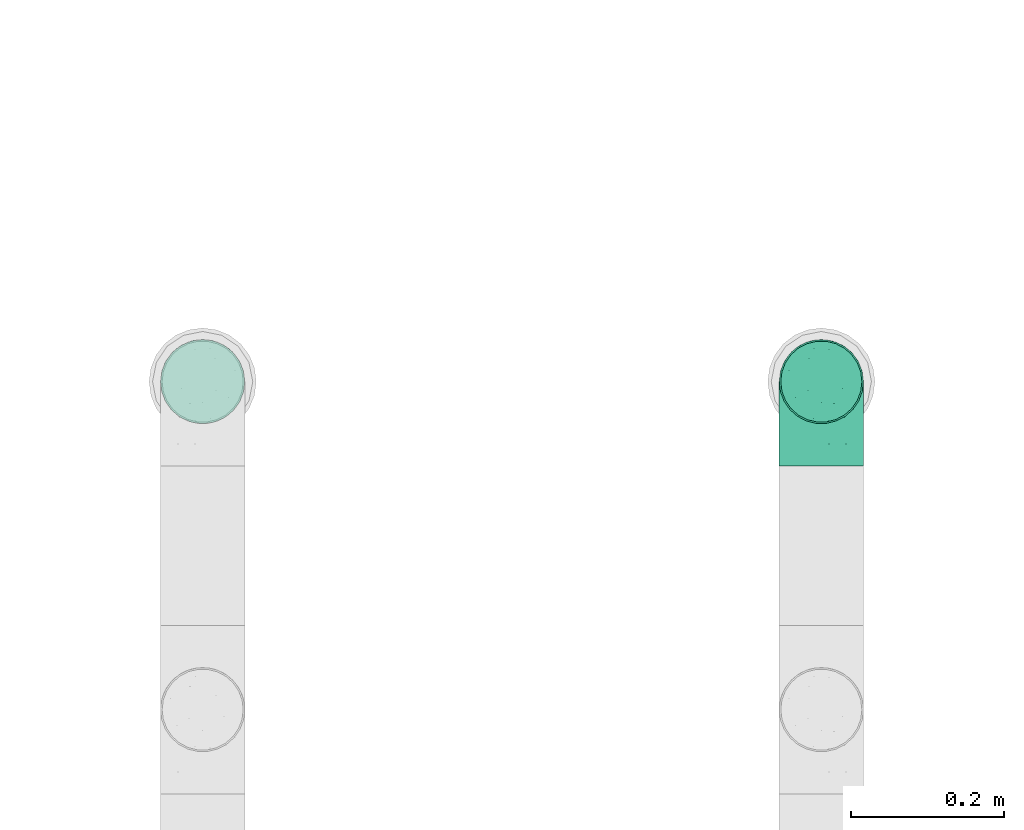
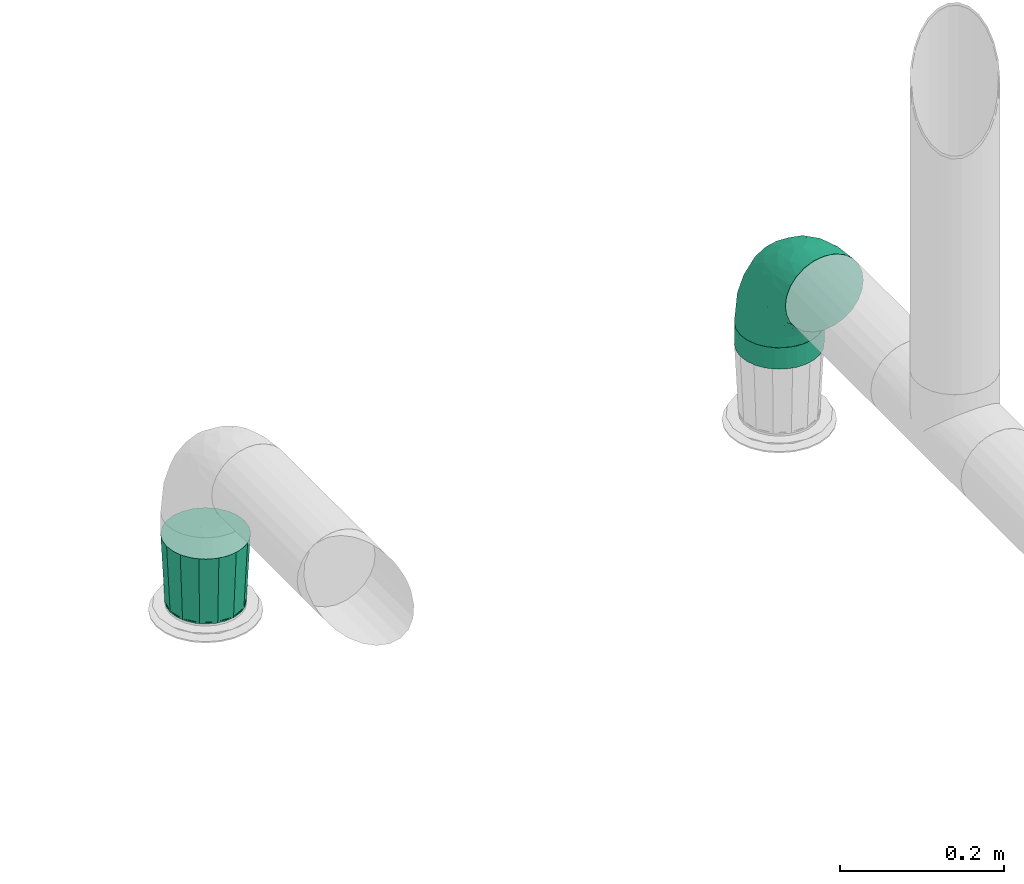
# One storey, part 15 of 103: 2 flow fittings, 1 flow segment.
"""IFC2X3 building model written with IfcOpenShell, lengths in millimetres."""

from ifc_helpers import new_model, entity, si_unit, converted_unit, derived_unit, direction, frame, origin_with_axes, origin_2d_with_axis, place, context, subcontext, project, spatial, hollow_circle, extrude, open_shell, surface_model, source, transform, mapped, material, layer, layer_set, layer_usage, type_object, element, save


model = new_model("IFC2X3")

# Units and contexts
model_context = context("Model", 3, precision=1e-05, world=origin_with_axes(), true_north=direction((0.0, 1.0)))
body_context = subcontext(model_context, "Body", "Model", "MODEL_VIEW")
ifc_project = project(units=[si_unit("AREAUNIT", "SQUARE_METRE"), si_unit("VOLUMEUNIT", "CUBIC_METRE", prefix="DECI"), si_unit("TIMEUNIT", "SECOND"), si_unit("THERMODYNAMICTEMPERATUREUNIT", "DEGREE_CELSIUS"), si_unit("PRESSUREUNIT", "PASCAL"), si_unit("MASSUNIT", "GRAM", prefix="KILO"), si_unit("LENGTHUNIT", "METRE", prefix="MILLI"), si_unit("POWERUNIT", "WATT"), si_unit("ELECTRICCURRENTUNIT", "AMPERE"), si_unit("ELECTRICVOLTAGEUNIT", "VOLT"), derived_unit("VOLUMETRICFLOWRATEUNIT", [(si_unit("VOLUMEUNIT", "CUBIC_METRE", prefix="DECI"), 1), (si_unit("TIMEUNIT", "SECOND"), -1)]), derived_unit("LINEARVELOCITYUNIT", [(si_unit("LENGTHUNIT", "METRE"), 1), (si_unit("TIMEUNIT", "SECOND"), -1)]), derived_unit("MASSDENSITYUNIT", [(si_unit("MASSUNIT", "GRAM", prefix="KILO"), 1), (si_unit("VOLUMEUNIT", "CUBIC_METRE"), -1)]), converted_unit("PLANEANGLEUNIT", "DEGREE", entity("IfcRatioMeasure", 0.01745), si_unit("PLANEANGLEUNIT", "RADIAN"), dimensions=[0, 0, 0, 0, 0, 0, 0])], contexts=[model_context])

# Site, building, storey
site_placement = place(None, origin_with_axes())
site = spatial("IfcSite", under=ifc_project, at=site_placement, CompositionType="ELEMENT")
building_placement = place(site_placement, origin_with_axes())
building = spatial("IfcBuilding", under=site, at=building_placement, Name="mc-building", CompositionType="ELEMENT")
storey_placement = place(building_placement, frame((0.0, 0.0, 5900.0), z_axis=(0.0, 0.0, 1.0), x_axis=(1.0, 0.0, 0.0)))
storey = spatial("IfcBuildingStorey", under=building, at=storey_placement, Name="3. Korrus", CompositionType="ELEMENT", Elevation=5900.0)

# Flow segment
ifc_material = material(Name="FZ1")
ifc_layer = layer(ifc_material, 0.0)
ifc_layer_set = layer_set([ifc_layer], Name="FZ1")
ifc_layer_usage = layer_usage(ifc_layer_set, "AXIS1", "POSITIVE", 0.0)
duct_segment_type = type_object("IfcDuctSegmentType", PredefinedType="RIGIDSEGMENT")
shared_shape_1 = source(origin_with_axes(), body_context, "Body", "SweptSolid", [
    extrude(hollow_circle(Radius=55.0, WallThickness=2.0, at=origin_2d_with_axis()), frame((0.0, 0.0, 0.0), z_axis=(1.0, 0.0, 0.0), x_axis=(0.0, 1.0, 0.0)), (0.0, 0.0, 1.0), 31.9),
])
flow_segment_placement = place(storey_placement, frame((9194.13313, 4730.85862, 2235.0), z_axis=(0.0, -1.0, 0.0), x_axis=(0.0, 0.0, -1.0)))
element("IfcFlowSegment", 1, at=flow_segment_placement, inside=storey, type_object=duct_segment_type, material=ifc_layer_usage, context=body_context, shape_type="MappedRepresentation", body=[
    mapped(shared_shape_1, transform((0.0, 0.0, 0.0), scale=1.0)),
])

# Flow fittings
duct_fitting_type_1 = type_object("IfcDuctFittingType", Name="BU", PredefinedType="BEND")
shared_shape_2 = source(origin_with_axes(), body_context, "Body", "SurfaceModel", [
    surface_model("IfcShellBasedSurfaceModel", [(-110.0, 0.0, -55.0), (-110.0, -14.23505, -53.12592), (-110.0, 14.23505, -53.12592), (-110.0, 53.12592, 14.23505), (-110.0, 27.5, -47.63139), (-110.0, 38.89087, -38.89087), (-110.0, -55.0, 0.0), (-110.0, -53.12592, 14.23505), (-110.0, -38.89087, -38.89087), (-110.0, -27.5, -47.63139), (-110.0, -53.12592, -14.23505), (-110.0, -47.63139, -27.5), (-110.0, -14.23505, 53.12592), (-110.0, 14.23505, 53.12592), (-110.0, 27.5, 47.63139), (-110.0, -47.63139, 27.5), (-110.0, -38.89087, 38.89087), (-110.0, -27.5, 47.63139), (-110.0, 0.0, 55.0), (-110.0, 55.0, 0.0), (-110.0, 53.12592, -14.23505), (-110.0, 47.63139, -27.5), (-110.0, 47.63139, 27.5), (-110.0, 38.89087, 38.89087), (-14.23505, 110.0, -53.12592), (-55.0, 110.0, 0.0), (0.0, 110.0, -55.0), (-27.5, 110.0, -47.63139), (-38.89087, 110.0, -38.89087), (-47.63139, 110.0, -27.5), (38.89087, 110.0, -38.89087), (53.12592, 110.0, 14.23505), (27.5, 110.0, -47.63139), (14.23505, 110.0, -53.12592), (47.63139, 110.0, -27.5), (53.12592, 110.0, -14.23505), (55.0, 110.0, 0.0), (-53.12592, 110.0, -14.23505), (-53.12592, 110.0, 14.23505), (-47.63139, 110.0, 27.5), (-38.89087, 110.0, 38.89087), (-27.5, 110.0, 47.63139), (0.0, 110.0, 55.0), (-14.23505, 110.0, 53.12592), (38.89087, 110.0, 38.89087), (47.63139, 110.0, 27.5), (27.5, 110.0, 47.63139), (14.23505, 110.0, 53.12592), (-64.21732, 48.68956, 43.63444), (-76.6405, 38.18013, 45.55988), (-60.44912, 32.56953, 51.94617), (-76.00813, 5.38378, 55.0), (-90.15553, 11.94394, 54.09138), (-78.5998, 26.77405, 50.81338), (-70.18771, 18.55163, 54.03432), (-75.55424, 54.2118, 32.41257), (-93.27622, 45.77614, 33.48188), (-96.12334, 22.13664, 50.81337), (-21.00813, 45.34362, 55.0), (-18.36258, 70.48427, 54.04484), (-32.04182, 59.64019, 52.24446), (-63.88653, 74.77858, 17.99134), (-74.66383, 63.08407, 19.92123), (-63.60674, 66.07878, 29.97482), (-99.597, 52.72185, 18.52927), (-93.11138, 56.59448, 10.50359), (-98.21577, 57.34403, 0.0), (-53.42855, 92.60092, 21.04759), (-88.54852, 54.8376, 21.04759), (-11.86161, 90.23965, 54.10313), (-5.38378, 76.00813, 55.0), (-57.34403, 98.21577, 0.0), (-56.64619, 93.12774, 10.22088), (-45.34362, 21.00813, 55.0), (-44.60838, 44.60838, 52.13415), (-92.68484, 35.46673, 43.63443), (-22.25266, 95.40765, 50.81337), (-35.97783, 90.61597, 43.63443), (-43.70931, 69.58671, 44.47149), (-27.23711, 77.39884, 50.81337), (-57.2828, 79.3123, 24.9774), (-58.67786, 84.31125, 16.04456), (-82.93277, 60.36161, 12.91784), (-49.88337, 54.51816, 47.224), (-74.57753, 66.83759, 9.55742), (-45.35812, 94.97281, 33.48188), (-59.18663, 88.95241, 0.0), (-51.517, 78.6292, 33.48188), (-65.14788, 80.03077, 0.0), (-56.45322, 62.06476, 39.63545), (-88.95241, 59.18663, 0.0), (-71.10913, 71.10913, 0.0), (-80.03077, 65.14788, 0.0), (-94.9309, 45.36788, -33.48188), (-93.11358, 56.60141, -10.46614), (-99.64997, 52.79499, -18.30015), (-90.20425, 36.08686, -43.63443), (-79.99933, 46.56772, -37.92748), (-76.00813, 5.38378, -55.0), (-72.75364, 19.68651, -53.60527), (-45.34362, 21.00813, -55.0), (-21.91957, 65.12078, -53.85897), (-5.38378, 76.00813, -55.0), (-21.00813, 45.34362, -55.0), (-35.41876, 92.89265, -43.63443), (-91.10309, 11.02766, -54.21832), (-45.77614, 93.27622, -33.48188), (-90.50474, 23.21022, -50.81337), (-70.92854, 33.31794, -49.51754), (-78.52933, 63.35627, -11.73997), (-24.91508, 84.05606, -50.81337), (-88.78941, 54.74452, -21.04759), (-69.59921, 57.34866, -33.48187), (-73.36422, 62.46673, -22.94182), (-63.49062, 67.59111, -28.46929), (-56.59448, 93.11138, -10.50359), (-54.8376, 88.54852, -21.04759), (-54.10679, 75.85581, -32.31867), (-57.75956, 31.09612, -52.80882), (-52.72185, 99.597, -18.52927), (-12.62913, 89.46304, -53.99097), (-34.46825, 66.46123, -50.04329), (-43.9837, 43.9837, -52.42279), (-65.78527, 72.58348, -17.68796), (-70.34468, 43.65295, -44.21951), (-57.47001, 51.99467, -44.91465), (-60.72547, 82.29174, -12.88567), (-42.34915, 74.24548, -43.63444), (-57.25194, 63.5016, -38.08211), (-80.95344, 53.56991, -29.32027), (-52.32891, 4.55257, -54.0482), (32.52942, 47.13398, -30.48571), (14.88266, 20.92917, -33.7947), (14.95561, 36.05775, -42.26543), (30.24048, 70.09027, -41.7461), (19.3559, 65.35825, -48.00507), (-70.35075, -46.44478, -19.5952), (-47.13398, -32.52942, -30.48571), (-28.49299, -30.5778, -16.4009), (-4.55257, 52.32891, -54.0482), (-22.4954, 22.4954, -53.25347), (-75.47368, -11.22546, -52.60718), (-81.32209, -51.5606, -9.98467), (-80.81763, -41.84862, -32.14655), (-70.09027, -30.24048, -41.7461), (-36.05774, -14.95561, -42.26543), (-9.15831, -10.852, -27.8997), (-65.35825, -19.3559, -48.00507), (11.22546, 75.47368, -52.60718), (3.94376, 43.9333, -50.53315), (-13.39742, 13.39743, -48.13058), (-43.9333, -3.94376, -50.53315), (49.37776, 67.29486, 0.0), (41.8609, 47.82256, -9.92641), (50.20582, 74.51695, -9.9731), (18.93131, 11.7156, -17.56239), (-27.5, -32.89419, 0.0), (-1.23348, -12.25375, -12.18106), (41.84862, 80.81763, -32.14655), (35.70604, 41.31408, -20.38235), (46.44478, 70.35075, -19.5952), (32.89419, 27.5, 0.0), (6.67262, -6.67262, 0.0), (-67.29486, -49.37776, 0.0), (-50.36265, -42.95545, -9.51562), (-5.47251, 5.47251, -39.92906), (-70.35075, -46.44478, 19.5952), (-74.51695, -50.20582, 9.9731), (-41.31407, -35.70604, 20.38235), (-47.13398, -32.52942, 30.48571), (-80.81763, -41.84862, 32.14655), (-4.55257, 52.32891, 54.0482), (11.22546, 75.47368, 52.60718), (-43.9333, -3.94376, 50.53315), (-65.35825, -19.3559, 48.00507), (-36.05774, -14.95561, 42.26543), (-70.09027, -30.24048, 41.7461), (-11.7156, -18.93131, 17.56239), (30.5778, 28.49299, 16.4009), (12.25375, 1.23348, 12.18106), (51.5606, 81.32209, 9.98467), (42.95545, 50.36265, 9.51562), (-75.47368, -11.22546, 52.60718), (-52.32891, 4.55257, 54.0482), (3.94376, 43.9333, 50.53315), (-22.4954, 22.4954, 53.25347), (-13.39742, 13.39743, 48.13058), (10.852, 9.15831, 27.8997), (-20.92916, -14.88266, 33.79469), (-47.82256, -41.8609, 9.92641), (32.52942, 47.13398, 30.48571), (46.44478, 70.35075, 19.5952), (41.84862, 80.81763, 32.14655), (30.24048, 70.09027, 41.7461), (19.3559, 65.35825, 48.00507), (14.95561, 36.05775, 42.26543), (-5.47251, 5.47251, 39.92906)], [open_shell([[[0, 1, 2]], [[2, 3, 4]], [[4, 3, 5]], [[2, 6, 7]], [[8, 6, 9]], [[1, 9, 6]], [[10, 6, 11]], [[8, 11, 6]], [[6, 2, 1]], [[12, 13, 14]], [[15, 2, 7]], [[16, 17, 2]], [[2, 17, 12]], [[12, 18, 13]], [[19, 20, 3]], [[5, 3, 21]], [[20, 21, 3]], [[22, 3, 2]], [[23, 22, 2]], [[12, 14, 2]], [[2, 14, 23]], [[15, 16, 2]], [[24, 25, 26]], [[27, 25, 24]], [[25, 28, 29]], [[28, 25, 27]], [[30, 26, 31]], [[26, 30, 32]], [[32, 33, 26]], [[34, 31, 35]], [[31, 34, 30]], [[35, 31, 36]], [[29, 37, 25]], [[38, 39, 26]], [[39, 40, 26]], [[41, 42, 40]], [[42, 26, 40]], [[42, 41, 43]], [[26, 44, 45]], [[31, 26, 45]], [[26, 46, 44]], [[47, 46, 26]], [[42, 47, 26]], [[25, 38, 26]], [[48, 49, 50]], [[18, 51, 52]], [[53, 54, 50]], [[55, 56, 49]], [[56, 22, 23]], [[13, 57, 14]], [[58, 59, 60]], [[61, 62, 63]], [[3, 64, 65]], [[53, 52, 54]], [[3, 65, 66]], [[67, 39, 38]], [[56, 68, 64]], [[65, 64, 68]], [[69, 59, 70]], [[38, 71, 72]], [[73, 58, 74]], [[75, 49, 56]], [[76, 69, 43]], [[53, 57, 52]], [[77, 78, 79]], [[41, 76, 43]], [[43, 69, 42]], [[55, 68, 56]], [[23, 14, 75]], [[76, 77, 79]], [[80, 67, 81]], [[62, 82, 68]], [[60, 78, 83]], [[62, 84, 82]], [[85, 77, 40]], [[81, 67, 72]], [[86, 72, 71]], [[87, 85, 67]], [[61, 81, 88]], [[77, 41, 40]], [[78, 77, 87]], [[23, 75, 56]], [[83, 89, 48]], [[85, 40, 39]], [[62, 68, 55]], [[89, 87, 63]], [[83, 48, 50]], [[57, 75, 14]], [[49, 75, 53]], [[67, 85, 39]], [[87, 77, 85]], [[63, 62, 55]], [[89, 55, 48]], [[80, 63, 87]], [[66, 65, 90]], [[66, 19, 3]], [[84, 91, 92]], [[92, 90, 82]], [[65, 82, 90]], [[61, 84, 62]], [[92, 82, 84]], [[68, 82, 65]], [[3, 22, 64]], [[56, 64, 22]], [[38, 25, 71]], [[81, 72, 86]], [[38, 72, 67]], [[91, 61, 88]], [[80, 81, 61]], [[63, 80, 61]], [[67, 80, 87]], [[77, 76, 41]], [[79, 59, 69]], [[79, 69, 76]], [[42, 69, 70]], [[60, 59, 79]], [[58, 70, 59]], [[78, 60, 79]], [[58, 60, 74]], [[52, 57, 13]], [[75, 57, 53]], [[18, 52, 13]], [[52, 51, 54]], [[51, 73, 54]], [[50, 73, 74]], [[73, 50, 54]], [[50, 74, 83]], [[60, 83, 74]], [[89, 83, 78]], [[87, 89, 78]], [[55, 89, 63]], [[50, 49, 53]], [[55, 49, 48]], [[81, 86, 88]], [[91, 84, 61]], [[5, 21, 93]], [[90, 94, 66]], [[20, 94, 95]], [[96, 93, 97]], [[98, 99, 100]], [[96, 4, 5]], [[101, 102, 103]], [[28, 27, 104]], [[2, 105, 0]], [[104, 106, 28]], [[99, 105, 107]], [[108, 107, 96]], [[90, 109, 94]], [[107, 2, 4]], [[20, 66, 94]], [[27, 24, 110]], [[109, 111, 94]], [[112, 113, 114]], [[37, 115, 71]], [[116, 106, 117]], [[99, 118, 100]], [[116, 115, 119]], [[37, 119, 115]], [[24, 120, 110]], [[121, 110, 101]], [[119, 106, 116]], [[101, 110, 120]], [[122, 103, 100]], [[117, 123, 116]], [[124, 125, 108]], [[115, 116, 126]], [[106, 29, 28]], [[26, 102, 120]], [[127, 104, 110]], [[97, 124, 96]], [[125, 122, 118]], [[128, 127, 125]], [[96, 5, 93]], [[115, 126, 86]], [[117, 106, 127]], [[111, 113, 129]], [[95, 93, 21]], [[97, 129, 112]], [[110, 104, 27]], [[106, 104, 127]], [[96, 107, 4]], [[99, 107, 108]], [[99, 108, 118]], [[105, 99, 98]], [[112, 114, 128]], [[121, 125, 127]], [[20, 19, 66]], [[109, 90, 92]], [[94, 111, 95]], [[91, 123, 109]], [[129, 113, 112]], [[93, 95, 111]], [[21, 20, 95]], [[71, 115, 86]], [[71, 25, 37]], [[123, 91, 88]], [[126, 116, 123]], [[123, 88, 126]], [[86, 126, 88]], [[37, 29, 119]], [[106, 119, 29]], [[129, 93, 111]], [[124, 112, 125]], [[0, 105, 98]], [[107, 105, 2]], [[125, 118, 108]], [[100, 118, 122]], [[93, 129, 97]], [[113, 111, 109]], [[109, 123, 113]], [[114, 123, 117]], [[123, 114, 113]], [[128, 114, 117]], [[127, 128, 117]], [[112, 128, 125]], [[103, 122, 101]], [[110, 121, 127]], [[101, 122, 121]], [[125, 121, 122]], [[26, 120, 24]], [[101, 120, 102]], [[96, 124, 108]], [[92, 91, 109]], [[112, 124, 97]], [[100, 130, 98]], [[131, 132, 133]], [[32, 134, 135]], [[136, 137, 138]], [[139, 140, 103]], [[98, 141, 0]], [[142, 10, 136]], [[143, 144, 137]], [[6, 10, 142]], [[137, 145, 146]], [[144, 147, 145]], [[143, 136, 11]], [[11, 136, 10]], [[8, 143, 11]], [[148, 149, 139]], [[8, 9, 144]], [[9, 1, 147]], [[130, 141, 98]], [[103, 140, 100]], [[148, 135, 149]], [[150, 151, 140]], [[152, 153, 154]], [[130, 140, 151]], [[148, 26, 33]], [[147, 1, 141]], [[155, 146, 132]], [[156, 138, 157]], [[134, 30, 158]], [[150, 140, 149]], [[158, 30, 34]], [[30, 134, 32]], [[153, 159, 160]], [[131, 160, 159]], [[144, 145, 137]], [[36, 152, 154]], [[146, 138, 137]], [[155, 161, 162]], [[158, 160, 131]], [[133, 149, 135]], [[156, 163, 164]], [[163, 142, 164]], [[139, 103, 102]], [[153, 152, 161]], [[34, 35, 160]], [[162, 157, 155]], [[132, 165, 133]], [[157, 146, 155]], [[140, 130, 100]], [[141, 130, 151]], [[141, 151, 147]], [[141, 1, 0]], [[102, 26, 148]], [[140, 139, 149]], [[102, 148, 139]], [[135, 33, 32]], [[151, 150, 145]], [[9, 147, 144]], [[151, 145, 147]], [[145, 165, 146]], [[135, 148, 33]], [[133, 135, 134]], [[131, 133, 134]], [[133, 165, 150]], [[133, 150, 149]], [[145, 150, 165]], [[132, 131, 159]], [[146, 165, 132]], [[160, 158, 34]], [[134, 158, 131]], [[144, 143, 8]], [[136, 143, 137]], [[155, 153, 161]], [[154, 153, 160]], [[153, 155, 159]], [[132, 159, 155]], [[160, 35, 154]], [[36, 154, 35]], [[164, 136, 138]], [[6, 142, 163]], [[136, 164, 142]], [[156, 164, 138]], [[156, 157, 162]], [[146, 157, 138]], [[15, 7, 166]], [[6, 163, 167]], [[168, 169, 166]], [[166, 169, 170]], [[171, 172, 70]], [[173, 174, 175]], [[17, 176, 174]], [[177, 156, 162]], [[176, 16, 170]], [[170, 16, 15]], [[161, 178, 179]], [[152, 180, 181]], [[182, 173, 183]], [[18, 12, 182]], [[184, 185, 186]], [[183, 185, 73]], [[183, 73, 51]], [[177, 187, 188]], [[189, 168, 166]], [[187, 178, 190]], [[16, 176, 17]], [[161, 152, 181]], [[45, 191, 31]], [[45, 44, 192]], [[192, 191, 45]], [[180, 36, 31]], [[193, 194, 195]], [[46, 47, 194]], [[193, 195, 190]], [[193, 44, 46]], [[172, 42, 70]], [[185, 58, 73]], [[189, 163, 156]], [[163, 189, 167]], [[70, 58, 171]], [[184, 171, 185]], [[169, 188, 175]], [[180, 31, 191]], [[192, 193, 190]], [[191, 190, 178]], [[182, 174, 173]], [[194, 47, 172]], [[190, 195, 187]], [[186, 185, 173]], [[162, 179, 177]], [[188, 196, 175]], [[179, 187, 177]], [[185, 171, 58]], [[172, 171, 184]], [[172, 184, 194]], [[172, 47, 42]], [[51, 18, 182]], [[185, 183, 173]], [[51, 182, 183]], [[174, 12, 17]], [[184, 186, 195]], [[46, 194, 193]], [[184, 195, 194]], [[195, 196, 187]], [[174, 182, 12]], [[175, 174, 176]], [[169, 175, 176]], [[175, 196, 186]], [[175, 186, 173]], [[195, 186, 196]], [[188, 169, 168]], [[187, 196, 188]], [[166, 170, 15]], [[176, 170, 169]], [[193, 192, 44]], [[191, 192, 190]], [[177, 189, 156]], [[167, 189, 166]], [[189, 177, 168]], [[188, 168, 177]], [[166, 7, 167]], [[6, 167, 7]], [[181, 191, 178]], [[36, 180, 152]], [[191, 181, 180]], [[161, 181, 178]], [[161, 179, 162]], [[187, 179, 178]]])]),
])
flow_fitting_1_placement = place(storey_placement, frame((9194.13313, 4730.85862, 2345.0), z_axis=(-1.0, 0.0, 0.0), x_axis=(0.0, 1.0, 0.0)))
element("IfcFlowFitting", 2, at=flow_fitting_1_placement, inside=storey, type_object=duct_fitting_type_1, Name="BU", context=body_context, shape_type="MappedRepresentation", body=[
    mapped(shared_shape_2, transform((0.0, 0.0, 0.0), scale=1.0)),
])
duct_fitting_type_2 = type_object("IfcDuctFittingType", PredefinedType="TRANSITION")
shared_shape_3 = source(origin_with_axes(), body_context, "Body", "SurfaceModel", [
    surface_model("IfcShellBasedSurfaceModel", [(100.0, -55.0, 0.0), (100.0, -12.23865, 53.62104), (100.0, -34.29194, 43.00073), (100.0, 49.55329, 23.86361), (100.0, 34.29194, 43.00073), (100.0, 49.55329, -23.86361), (0.0, -45.04844, -21.69419), (0.0, -50.0, 0.0), (0.0, -45.04844, 21.69419), (0.0, 31.17449, 39.09157), (0.0, 45.04844, 21.69419), (0.0, 50.0, 0.0), (98.0, 47.63139, 27.5), (98.0, 0.0, 55.0), (98.0, 38.89087, 38.89087), (98.0, -38.89087, 38.89087), (98.0, -47.63139, 27.5), (100.0, 12.23865, 53.62104), (100.0, -49.55329, 23.86361), (100.0, 55.0, 0.0), (100.0, 12.23865, -53.62104), (100.0, 34.29194, -43.00073), (100.0, -49.55329, -23.86361), (100.0, -34.29194, -43.00073), (100.0, -12.23865, -53.62104), (0.0, -31.17449, 39.09157), (0.0, -11.12605, 48.7464), (0.0, 11.12605, 48.7464), (0.0, -31.17449, -39.09157), (0.0, 11.12605, -48.7464), (0.0, -11.12605, -48.7464), (0.0, 45.04844, -21.69419), (0.0, 31.17449, -39.09157), (0.0, 47.52422, -10.84709), (0.0, 38.11147, -30.39288), (100.0, 41.92261, -33.43217), (100.0, -41.92261, -33.43217), (0.0, -38.11147, -30.39288), (100.0, 23.2653, -48.31088), (0.0, 21.15027, -43.91899), (100.0, 52.32388, -11.72483), (0.0, 0.0, -48.7464), (100.0, 0.0, -53.62104), (0.0, -21.15027, -43.91899), (100.0, -23.2653, -48.31088), (0.0, -47.52422, -10.84709), (100.0, -52.32388, -11.72483), (0.0, -47.52422, 10.84709), (0.0, -38.11147, 30.39288), (100.0, -41.92261, 33.43217), (100.0, 41.92261, 33.43217), (0.0, 38.11147, 30.39288), (100.0, -23.2653, 48.31088), (0.0, -21.15027, 43.91899), (100.0, -52.32388, 11.72483), (0.0, 0.0, 48.7464), (100.0, 0.0, 53.62104), (0.0, 21.15027, 43.91899), (100.0, 23.2653, 48.31088), (0.0, 47.52422, 10.84709), (100.0, 52.32388, 11.72483), (100.0, -14.23505, -53.12592), (100.0, 0.0, -55.0), (100.0, -27.5, -47.63139), (100.0, 27.5, -47.63139), (100.0, -38.89087, -38.89087), (100.0, -53.12592, -14.23505), (100.0, -47.63139, -27.5), (100.0, -47.63139, 27.5), (100.0, 14.23505, -53.12592), (100.0, 38.89087, -38.89087), (100.0, 47.63139, -27.5), (100.0, 47.63139, 27.5), (100.0, 53.12592, -14.23505), (100.0, -53.12592, 14.23505), (100.0, -38.89087, 38.89087), (100.0, -27.5, 47.63139), (100.0, 0.0, 55.0), (100.0, -14.23505, 53.12592), (100.0, 53.12592, 14.23505), (100.0, 38.89087, 38.89087), (100.0, 27.5, 47.63139), (100.0, 14.23505, 53.12592), (98.0, -27.5, 47.63139), (98.0, -14.23505, 53.12592), (98.0, -53.12592, -14.23505), (98.0, 14.23505, 53.12592), (98.0, 27.5, 47.63139), (98.0, 53.12592, 14.23505), (98.0, 55.0, 0.0), (98.0, -47.63139, -27.5), (98.0, -53.12592, 14.23505), (98.0, 27.5, -47.63139), (98.0, -27.5, -47.63139), (98.0, -38.89087, -38.89087), (98.0, 0.0, -55.0), (98.0, -14.23505, -53.12592), (98.0, 38.89087, -38.89087), (98.0, 47.63139, -27.5), (98.0, 53.12592, -14.23505), (98.0, 14.23505, -53.12592), (98.0, -55.0, 0.0), (0.0, 0.0, 50.0), (0.0, 35.35534, 35.35534), (0.0, -12.94095, 48.29629), (0.0, -25.0, 43.30127), (0.0, -35.35534, 35.35534), (0.0, -48.29629, 12.94095), (0.0, -43.30127, 25.0), (0.0, 25.0, 43.30127), (0.0, 12.94095, 48.29629), (0.0, 43.30127, 25.0), (0.0, 48.29629, 12.94095), (0.0, 25.0, -43.30127), (0.0, 48.29629, -12.94095), (0.0, -48.29629, -12.94095), (0.0, -43.30127, -25.0), (0.0, -12.94095, -48.29629), (0.0, -25.0, -43.30127), (0.0, -35.35534, -35.35534), (0.0, 43.30127, -25.0), (0.0, 35.35534, -35.35534), (0.0, 12.94095, -48.29629), (0.0, 0.0, -50.0), (2.0, -35.35534, -35.35534), (2.0, -25.0, -43.30127), (2.0, -12.94095, -48.29629), (2.0, -43.30127, -25.0), (2.0, 0.0, -50.0), (2.0, -48.29629, -12.94095), (2.0, -50.0, 0.0), (2.0, 12.94095, -48.29629), (2.0, 25.0, -43.30127), (2.0, 43.30127, -25.0), (2.0, 48.29629, -12.94095), (2.0, 35.35534, -35.35534), (2.0, -48.29629, 12.94095), (2.0, -35.35534, 35.35534), (2.0, -43.30127, 25.0), (2.0, 35.35534, 35.35534), (2.0, -12.94095, 48.29629), (2.0, -25.0, 43.30127), (2.0, 0.0, 50.0), (2.0, 43.30127, 25.0), (2.0, 48.29629, 12.94095), (2.0, 50.0, 0.0), (2.0, 25.0, 43.30127), (2.0, 12.94095, 48.29629)], [open_shell([[[0, 1, 2]], [[3, 4, 5]], [[6, 7, 8]], [[9, 10, 11]], [[12, 13, 14]], [[15, 13, 16]], [[0, 4, 17]], [[2, 18, 0]], [[1, 0, 17]], [[3, 5, 19]], [[20, 21, 5]], [[22, 20, 5]], [[22, 5, 0]], [[22, 23, 24]], [[22, 24, 20]], [[4, 0, 5]], [[8, 25, 6]], [[6, 25, 26]], [[6, 26, 27]], [[11, 27, 9]], [[28, 6, 29]], [[30, 28, 29]], [[31, 6, 11]], [[31, 32, 29]], [[31, 29, 6]], [[27, 11, 6]], [[31, 33, 5]], [[34, 35, 32]], [[36, 22, 6]], [[36, 37, 23]], [[38, 29, 39]], [[33, 40, 5]], [[33, 11, 40]], [[19, 40, 11]], [[32, 21, 39]], [[32, 35, 21]], [[34, 31, 35]], [[30, 41, 42]], [[28, 43, 44]], [[42, 41, 20]], [[7, 45, 46]], [[38, 39, 21]], [[46, 0, 7]], [[6, 37, 36]], [[38, 20, 29]], [[43, 30, 24]], [[42, 24, 30]], [[28, 23, 37]], [[6, 22, 45]], [[35, 31, 5]], [[44, 43, 24]], [[20, 41, 29]], [[46, 45, 22]], [[44, 23, 28]], [[8, 47, 18]], [[48, 49, 25]], [[50, 3, 10]], [[50, 51, 4]], [[52, 26, 53]], [[47, 54, 18]], [[47, 7, 54]], [[0, 54, 7]], [[25, 2, 53]], [[25, 49, 2]], [[48, 8, 49]], [[27, 55, 56]], [[9, 57, 58]], [[56, 55, 1]], [[11, 59, 60]], [[52, 53, 2]], [[60, 19, 11]], [[10, 51, 50]], [[52, 1, 26]], [[57, 27, 17]], [[56, 17, 27]], [[9, 4, 51]], [[10, 3, 59]], [[49, 8, 18]], [[58, 57, 17]], [[1, 55, 26]], [[60, 59, 3]], [[58, 4, 9]], [[61, 62, 63]], [[63, 64, 65]], [[66, 67, 68]], [[65, 64, 67]], [[67, 64, 68]], [[69, 64, 62]], [[64, 63, 62]], [[70, 71, 64]], [[72, 64, 71]], [[71, 73, 19]], [[74, 0, 66]], [[72, 68, 64]], [[75, 68, 76]], [[77, 78, 76]], [[72, 76, 68]], [[76, 72, 77]], [[79, 72, 19]], [[19, 72, 71]], [[80, 81, 77]], [[77, 72, 80]], [[82, 77, 81]], [[74, 66, 68]], [[83, 84, 13]], [[15, 83, 13]], [[12, 16, 13]], [[16, 12, 85]], [[86, 87, 13]], [[87, 14, 13]], [[88, 89, 12]], [[89, 90, 12]], [[91, 16, 85]], [[90, 85, 12]], [[89, 92, 90]], [[93, 94, 95]], [[95, 94, 90]], [[96, 93, 95]], [[97, 92, 98]], [[98, 89, 99]], [[100, 95, 92]], [[92, 89, 98]], [[90, 92, 95]], [[101, 91, 85]], [[89, 73, 99]], [[99, 71, 98]], [[92, 97, 64]], [[70, 97, 98]], [[100, 92, 69]], [[73, 71, 99]], [[89, 19, 73]], [[92, 64, 69]], [[64, 97, 70]], [[98, 71, 70]], [[100, 69, 62]], [[62, 95, 100]], [[95, 61, 96]], [[96, 63, 93]], [[90, 94, 67]], [[65, 94, 93]], [[85, 90, 66]], [[63, 65, 93]], [[96, 61, 63]], [[85, 66, 0]], [[66, 90, 67]], [[94, 65, 67]], [[85, 0, 101]], [[62, 61, 95]], [[101, 74, 91]], [[91, 68, 16]], [[83, 15, 76]], [[75, 15, 16]], [[84, 83, 78]], [[74, 68, 91]], [[101, 0, 74]], [[83, 76, 78]], [[76, 15, 75]], [[16, 68, 75]], [[84, 78, 77]], [[77, 13, 84]], [[13, 82, 86]], [[86, 81, 87]], [[12, 14, 72]], [[80, 14, 87]], [[88, 12, 79]], [[81, 80, 87]], [[86, 82, 81]], [[88, 79, 19]], [[79, 12, 72]], [[14, 80, 72]], [[88, 19, 89]], [[77, 82, 13]], [[102, 103, 104]], [[105, 104, 106]], [[107, 108, 106]], [[103, 106, 104]], [[106, 103, 107]], [[109, 103, 110]], [[103, 102, 110]], [[111, 112, 103]], [[113, 103, 112]], [[112, 11, 114]], [[107, 103, 113]], [[113, 115, 107]], [[116, 115, 117]], [[117, 118, 119]], [[116, 117, 119]], [[117, 115, 113]], [[120, 121, 114]], [[113, 114, 121]], [[113, 122, 117]], [[113, 112, 114]], [[117, 122, 123]], [[7, 107, 115]], [[124, 125, 126]], [[127, 124, 126]], [[128, 129, 126]], [[127, 126, 129]], [[130, 129, 128]], [[131, 132, 128]], [[132, 130, 128]], [[133, 134, 135]], [[132, 135, 134]], [[132, 134, 130]], [[134, 136, 130]], [[137, 138, 136]], [[137, 136, 139]], [[140, 137, 139]], [[141, 137, 140]], [[142, 140, 139]], [[143, 139, 144]], [[144, 134, 145]], [[146, 147, 139]], [[139, 136, 144]], [[139, 147, 142]], [[136, 134, 144]], [[11, 134, 114]], [[114, 133, 120]], [[113, 121, 132]], [[135, 121, 120]], [[122, 113, 131]], [[134, 133, 114]], [[11, 145, 134]], [[113, 132, 131]], [[132, 121, 135]], [[120, 133, 135]], [[122, 131, 128]], [[128, 123, 122]], [[123, 126, 117]], [[117, 125, 118]], [[116, 119, 127]], [[124, 119, 118]], [[115, 116, 129]], [[125, 124, 118]], [[117, 126, 125]], [[115, 129, 130]], [[129, 116, 127]], [[119, 124, 127]], [[115, 130, 7]], [[128, 126, 123]], [[7, 136, 107]], [[107, 138, 108]], [[105, 106, 141]], [[137, 106, 108]], [[104, 105, 140]], [[136, 138, 107]], [[7, 130, 136]], [[105, 141, 140]], [[141, 106, 137]], [[108, 138, 137]], [[104, 140, 142]], [[142, 102, 104]], [[102, 147, 110]], [[110, 146, 109]], [[111, 103, 143]], [[139, 103, 109]], [[112, 111, 144]], [[146, 139, 109]], [[110, 147, 146]], [[112, 144, 145]], [[144, 111, 143]], [[103, 139, 143]], [[112, 145, 11]], [[142, 147, 102]]])]),
])
flow_fitting_2_placement = place(storey_placement, frame((8385.80789, 4730.85862, 2103.1), z_axis=(0.0, -1.0, 0.0), x_axis=(0.0, 0.0, 1.0)))
element("IfcFlowFitting", 3, at=flow_fitting_2_placement, inside=storey, type_object=duct_fitting_type_2, context=body_context, shape_type="MappedRepresentation", body=[
    mapped(shared_shape_3, transform((0.0, 0.0, 0.0), scale=1.0)),
])

save(model, "model.ifc")
